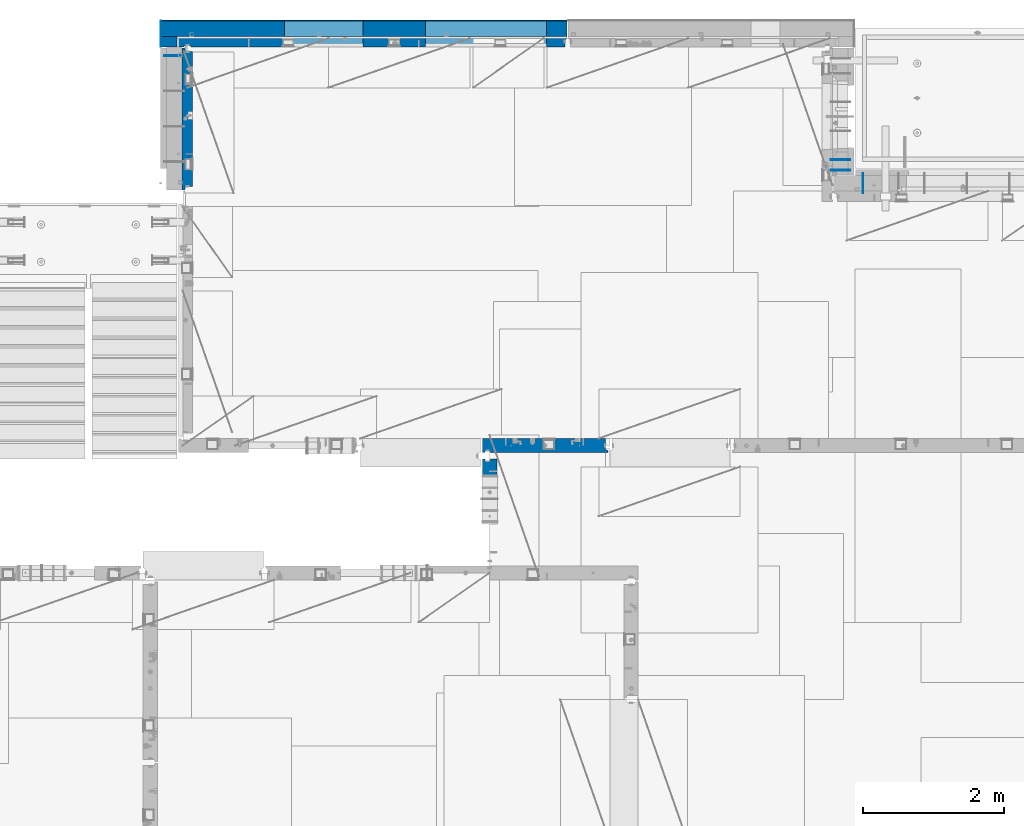
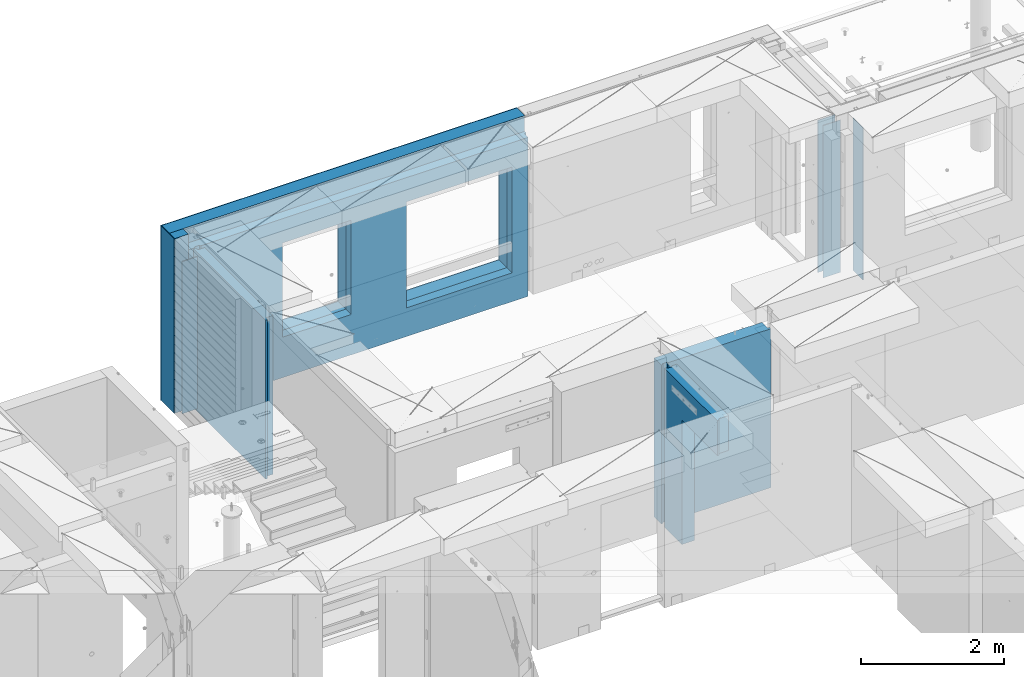
# One storey, part 228 of 334: 12 walls, 6 elements without a shape of their own.
"""IFC2X3 building model written with IfcOpenShell, lengths in millimetres."""

from ifc_helpers import new_model, si_unit, frame, origin_with_axes, place, context, subcontext, project, spatial, faceted_brep, material, type_object, element, aggregate, save


model = new_model("IFC2X3")

# Units and contexts
model_context = context("Model", 3, precision=1e-05, world=origin_with_axes())
body_context = subcontext(model_context, "Body", "Model", "MODEL_VIEW")
ifc_project = project(units=[si_unit("LENGTHUNIT", "METRE", prefix="MILLI"), si_unit("AREAUNIT", "SQUARE_METRE"), si_unit("VOLUMEUNIT", "CUBIC_METRE"), si_unit("MASSUNIT", "GRAM", prefix="KILO"), si_unit("TIMEUNIT", "SECOND"), si_unit("PLANEANGLEUNIT", "RADIAN"), si_unit("SOLIDANGLEUNIT", "STERADIAN"), si_unit("THERMODYNAMICTEMPERATUREUNIT", "DEGREE_CELSIUS"), si_unit("LUMINOUSINTENSITYUNIT", "LUMEN")], contexts=[model_context])

# Site, building, storey
site_placement = place(None, origin_with_axes())
site = spatial("IfcSite", under=ifc_project, at=site_placement, CompositionType="ELEMENT")
building_placement = place(site_placement, origin_with_axes())
building = spatial("IfcBuilding", under=site, at=building_placement, CompositionType="ELEMENT")
storey_placement = place(building_placement, origin_with_axes())
storey = spatial("IfcBuildingStorey", under=building, at=storey_placement, Name="3", CompositionType="ELEMENT", Elevation=0.0)

# Assembly, wall
assembly_1_placement = place(storey_placement, origin_with_axes())
assembly_1 = element("IfcElementAssembly", 1, at=assembly_1_placement, inside=storey, AssemblyPlace="NOTDEFINED", PredefinedType="REINFORCEMENT_UNIT")
ifc_material_1 = material(Name="Undefined")
wall_type_1 = type_object("IfcWallType", PredefinedType="NOTDEFINED")
wall_1_placement = place(assembly_1_placement, frame((22290.0, 22495.0, 89110.0), z_axis=(0.0, 0.0, 1.0), x_axis=(-1.0, 3.00000001838171e-08, 0.0)))
wall_1 = element("IfcWall", 2, at=wall_1_placement, type_object=wall_type_1, material=ifc_material_1, Name="(PD)", context=body_context, shape_type="Brep", body=[
    faceted_brep([(0.0, 5.0, -1300.0), (0.0, 5.0, 1300.0), (280.0, 5.0, 1300.0), (280.0, 5.0, -1300.0), (0.0, -5.0, 1300.0), (280.0, -5.0, 1300.0), (0.0, -5.0, -1300.0), (280.0, -5.0, -1300.0)], [[[0, 1, 2, 3]], [[1, 4, 5, 2]], [[4, 6, 7, 5]], [[6, 0, 3, 7]], [[5, 7, 3, 2]], [[6, 4, 1, 0]]]),
])

assembly_2_placement = place(storey_placement, origin_with_axes())
assembly_2 = element("IfcElementAssembly", 3, at=assembly_2_placement, inside=storey, AssemblyPlace="NOTDEFINED", PredefinedType="REINFORCEMENT_UNIT")
wall_2_placement = place(assembly_2_placement, frame((31890.0, 20549.9951872276, 89115.0), z_axis=(0.0, 0.0, 1.0), x_axis=(0.0, 1.0, 0.0)))
wall_2 = element("IfcWall", 4, at=wall_2_placement, type_object=wall_type_1, material=ifc_material_1, Name="(PD)", context=body_context, shape_type="Brep", body=[
    faceted_brep([(0.0, 5.0, -1300.0), (0.0, 5.0, 1300.0), (280.0, 5.0, 1300.0), (280.0, 5.0, -1300.0), (0.0, -5.0, 1300.0), (280.0, -5.0, 1300.0), (0.0, -5.0, -1300.0), (280.0, -5.0, -1300.0)], [[[0, 1, 2, 3]], [[1, 4, 5, 2]], [[4, 6, 7, 5]], [[6, 0, 3, 7]], [[5, 7, 3, 2]], [[6, 4, 1, 0]]]),
])
aggregate(assembly_2, [wall_2])

# Assembly, walls
assembly_3_placement = place(storey_placement, origin_with_axes())
assembly_3 = element("IfcElementAssembly", 5, at=assembly_3_placement, inside=storey, AssemblyPlace="NOTDEFINED", PredefinedType="REINFORCEMENT_UNIT")
wall_3_placement = place(assembly_3_placement, frame((31429.9951872276, 20875.0, 89115.0), z_axis=(0.0, 0.0, 1.0), x_axis=(1.0, 0.0, 0.0)))
wall_3 = element("IfcWall", 6, at=wall_3_placement, type_object=wall_type_1, material=ifc_material_1, Name="(PD)", context=body_context, shape_type="Brep", body=[
    faceted_brep([(0.0, 5.0, -1300.0), (0.0, 5.0, 1300.0), (280.0, 5.0, 1300.0), (280.0, 5.0, -1300.0), (0.0, -5.0, 1300.0), (280.0, -5.0, 1300.0), (0.0, -5.0, -1300.0), (280.0, -5.0, -1300.0)], [[[0, 1, 2, 3]], [[1, 4, 5, 2]], [[4, 6, 7, 5]], [[6, 0, 3, 7]], [[5, 7, 3, 2]], [[6, 4, 1, 0]]]),
])
wall_4_placement = place(assembly_3_placement, frame((31429.9951872276, 21025.0, 89115.0), z_axis=(0.0, 0.0, 1.0), x_axis=(1.0, 0.0, 0.0)))
wall_4 = element("IfcWall", 7, at=wall_4_placement, type_object=wall_type_1, material=ifc_material_1, Name="(PD)", context=body_context, shape_type="Brep", body=[
    faceted_brep([(0.0, 5.0, -1300.0), (0.0, 5.0, 1300.0), (280.0, 5.0, 1300.0), (280.0, 5.0, -1300.0), (0.0, -5.0, 1300.0), (280.0, -5.0, 1300.0), (0.0, -5.0, -1300.0), (280.0, -5.0, -1300.0)], [[[0, 1, 2, 3]], [[1, 4, 5, 2]], [[4, 6, 7, 5]], [[6, 0, 3, 7]], [[5, 7, 3, 2]], [[6, 4, 1, 0]]]),
])
aggregate(assembly_3, [wall_3, wall_4])

# Assembly, wall
assembly_4_placement = place(storey_placement, origin_with_axes())
assembly_4 = element("IfcElementAssembly", 8, at=assembly_4_placement, inside=storey, AssemblyPlace="NOTDEFINED", PredefinedType="REINFORCEMENT_UNIT")
ifc_material_2 = material(Name="CONCRETE/C25/30")
wall_type_2 = type_object("IfcWallType", PredefinedType="NOTDEFINED")
wall_5_placement = place(assembly_4_placement, frame((26609.9991475894, 15280.0004107749, 89112.5), z_axis=(0.0, 0.0, 1.0), x_axis=(0.0, 1.0, 0.0)))
wall_5 = element("IfcWall", 9, at=wall_5_placement, type_object=wall_type_2, material=ifc_material_2, context=body_context, shape_type="Brep", body=[
    faceted_brep([(1509.99949975397, 70.0, 1357.5), (1489.99949975397, 70.0, 1357.5), (1489.99949975397, 70.0, -1357.5), (1509.99949975397, 70.0, -1357.5), (1489.99949975397, -10.0, 1357.5), (1489.99949975397, -10.0, -1357.5), (1509.99949975397, -10.0, 1357.5), (1509.99949975397, -10.0, -1357.5), (29.9995892251427, 70.0, 1357.5), (29.9995892251427, 70.0, 762.5), (59.9995892251427, 57.0, 762.5), (59.9995892251427, 57.0, 1357.5), (29.9995892251427, 100.0, 1357.5), (29.9995892251427, 100.0, 762.5), (1509.99949975397, 100.0, 1357.5), (1509.99949975397, 100.0, -1357.5), (1019.99979369292, 100.0, -1357.5), (1019.99979369292, 100.0, 762.5), (1019.99979369292, -100.0, 762.5), (1019.99979369292, -100.0, -1357.5), (59.9995892251427, -100.0, 762.5), (59.9995892251427, -100.0, 1357.5), (1509.99949975397, -100.0, -1357.5), (1509.99949975397, -100.0, 1357.5)], [[[0, 1, 2, 3]], [[4, 5, 2, 1]], [[6, 7, 5, 4]], [[8, 9, 10, 11]], [[12, 13, 9, 8]], [[12, 14, 15, 16, 17, 13]], [[18, 17, 16, 19]], [[9, 13, 17, 18, 20, 10]], [[21, 11, 10, 20]], [[18, 19, 22, 23, 21, 20]], [[1, 0, 14, 12, 8, 11, 21, 23, 6, 4]], [[15, 14, 0, 3]], [[22, 19, 16, 15, 3, 2, 5, 7]], [[23, 22, 7, 6]]]),
])
aggregate(assembly_4, [wall_5])

assembly_5_placement = place(storey_placement, origin_with_axes())
assembly_5 = element("IfcElementAssembly", 10, at=assembly_5_placement, inside=storey, AssemblyPlace="NOTDEFINED", PredefinedType="REINFORCEMENT_UNIT")
wall_6_placement = place(assembly_5_placement, frame((26510.0014364077, 16980.0, 89112.5), z_axis=(0.0, 0.0, 1.0), x_axis=(1.0, 0.0, 0.0)))
wall_6 = element("IfcWall", 11, at=wall_6_placement, type_object=wall_type_2, material=ifc_material_2, context=body_context, shape_type="Brep", body=[
    faceted_brep([(1739.99847412109, 100.0, 1357.5), (1739.99847412109, -57.0, 1357.5), (1739.99847412109, -57.0, -1357.5), (1739.99847412109, 100.0, -1357.5), (1769.99847412109, -70.0, 1357.5), (1769.99847412109, -70.0, -1357.5), (0.0, -100.0, -1357.5), (0.0, -100.0, 1357.5), (0.0, 100.0, 1357.5), (0.0, 100.0, -1357.5), (29.998563592264, -100.0, -1357.5), (29.998563592264, -100.0, 1357.5), (29.998563592264, -80.0008544921875, -1357.5), (29.998563592264, -80.0008544921875, 1357.5), (109.998563592264, -80.0008544921875, -1357.5), (109.998563592264, -80.0008544921875, 1357.5), (109.998563592264, -100.0, -1357.5), (109.998563592264, -100.0, 1357.5), (1769.99847412109, -100.0, -1357.5), (1769.99847412109, -100.0, 1357.5)], [[[0, 1, 2, 3]], [[4, 5, 2, 1]], [[6, 7, 8, 9]], [[7, 6, 10, 11]], [[11, 10, 12, 13]], [[13, 12, 14, 15]], [[15, 14, 16, 17]], [[18, 19, 17, 16]], [[0, 8, 7, 11, 13, 15, 17, 19, 4, 1]], [[9, 8, 0, 3]], [[18, 16, 14, 12, 10, 6, 9, 3, 2, 5]], [[19, 18, 5, 4]]]),
])
aggregate(assembly_5, [wall_6])

# Assembly, walls
assembly_6_placement = place(storey_placement, origin_with_axes())
assembly_6 = element("IfcElementAssembly", 12, at=assembly_6_placement, inside=storey, AssemblyPlace="NOTDEFINED", PredefinedType="REINFORCEMENT_UNIT")
ifc_material_3 = material()
wall_type_3 = type_object("IfcWallType", PredefinedType="NOTDEFINED")
wall_7_placement = place(assembly_6_placement, frame((22075.0, 22620.0, 89247.5), z_axis=(0.0, 0.0, 1.0), x_axis=(0.0, 1.0, 0.0)))
wall_7 = element("IfcWall", 13, at=wall_7_placement, type_object=wall_type_3, material=ifc_material_3, context=body_context, shape_type="Brep", body=[
    faceted_brep([(0.0, 110.0, -1492.5), (0.0, 110.0, 1492.5), (150.0, 110.0, 1492.5), (150.0, 110.0, -1492.5), (0.0, -110.0, 1492.5), (150.0, -110.0, 1492.5), (0.0, -110.0, -1492.5), (150.0, -110.0, -1492.5)], [[[0, 1, 2, 3]], [[1, 4, 5, 2]], [[4, 6, 7, 5]], [[6, 0, 3, 7]], [[5, 7, 3, 2]], [[6, 4, 1, 0]]]),
])
wall_8_placement = place(assembly_6_placement, frame((22260.0, 22880.0, 89247.5), z_axis=(0.0, 0.0, 1.0), x_axis=(1.0, 0.0, 0.0)))
wall_8 = element("IfcWall", 14, at=wall_8_placement, type_object=wall_type_3, material=ifc_material_3, context=body_context, shape_type="Brep", body=[
    faceted_brep([(-295.0, 110.0, 1492.5), (-295.0, -110.0, 1492.5), (5445.0, -110.0, 1492.5), (5445.0, 110.0, 1492.5), (-295.0, -110.0, -1492.5), (-295.0, 110.0, -1492.5), (5445.0, 110.0, -1492.5), (5445.0, -110.0, -1492.5), (3445.00100868184, 110.0, -1002.5), (5155.00100868184, 110.0, -1002.5), (5155.00100868184, 110.0, 807.5), (3445.00100868184, 110.0, 807.5), (1444.99910133321, 110.0, -802.5), (2554.99910133321, 110.0, -802.5), (2554.99910133321, 110.0, 807.5), (1444.99910133321, 110.0, 807.5), (1444.99910133321, -110.0, -802.5), (2554.99910133321, -110.0, -802.5), (1444.99910133321, -110.0, 807.5), (2554.99910133321, -110.0, 807.5), (3445.00100868184, -110.0, -1002.5), (3445.00100868184, -110.0, 807.5), (5155.00100868184, -110.0, 807.5), (5155.00100868184, -110.0, -1002.5)], [[[0, 1, 2, 3]], [[4, 1, 0, 5]], [[4, 5, 6, 7]], [[2, 7, 6, 3]], [[5, 0, 3, 6], [8, 9, 10, 11], [12, 13, 14, 15]], [[12, 16, 17, 13]], [[15, 18, 16, 12]], [[14, 19, 18, 15]], [[13, 17, 19, 14]], [[1, 4, 7, 2], [20, 21, 22, 23], [16, 18, 19, 17]], [[10, 22, 21, 11]], [[9, 23, 22, 10]], [[8, 20, 23, 9]], [[11, 21, 20, 8]]]),
])
wall_type_4 = type_object("IfcWallType", PredefinedType="NOTDEFINED")
wall_9_placement = place(assembly_6_placement, frame((22185.0, 22695.0, 89112.5), z_axis=(0.0, 0.0, 1.0), x_axis=(1.0, 0.0, 0.0)))
wall_9 = element("IfcWall", 15, at=wall_9_placement, type_object=wall_type_4, material=ifc_material_2, context=body_context, shape_type="Brep", body=[
    faceted_brep([(3520.00100868184, 75.0, 942.5), (3520.00100868184, -75.0000008199713, 942.5), (3520.00100868184, -75.0000000602631, -867.5), (3520.00100868184, 75.0, -867.5), (5230.00100868184, -74.9999996918959, -867.5), (5230.00100868184, 75.0, -867.5), (5230.00100868184, -75.0000004516041, 942.5), (5230.00100868184, 75.0, 942.5), (5490.0, -75.0, 1357.5), (5490.0, -75.0, -1357.5), (5490.0, 24.9999980926514, -1357.5), (5490.0, 24.9999980926514, 1357.5), (5520.0, 45.0, 1357.5), (5520.0, 75.0, 1357.5), (0.0, 75.0, 1357.5), (0.0, -75.0, 1357.5), (100.0, -75.0, 1357.5), (110.0, -55.0000022791319, 1357.5), (190.0, -55.0000022791319, 1357.5), (200.0, -75.0000022791319, 1357.5), (0.0, -75.0, -1357.5), (0.0, 75.0, -1357.5), (100.0, -75.0, -1357.5), (110.0, -55.0000022791319, -1357.5), (190.0, -55.0000022791319, -1357.5), (200.0, -75.0, -1357.5), (5520.0, 75.0, -1357.5), (5520.0, 45.0, -1357.5), (1519.99910133321, 75.0, -667.5), (2629.99910133321, 75.0, -667.5), (2629.99910133321, 75.0, 942.5), (1519.99910133321, 75.0, 942.5), (1519.99910133321, -75.0000005750444, -667.5), (2629.99910133321, -75.0000003359273, -667.5), (1519.99910133321, -75.0000012508099, 942.5), (2629.99910133321, -75.0000010116928, 942.5)], [[[0, 1, 2, 3]], [[3, 2, 4, 5]], [[5, 4, 6, 7]], [[7, 6, 1, 0]], [[8, 9, 10, 11]], [[8, 11, 12, 13, 14, 15, 16, 17, 18, 19]], [[20, 15, 14, 21]], [[15, 20, 22, 16]], [[16, 22, 23, 17]], [[17, 23, 24, 18]], [[19, 18, 24, 25]], [[23, 22, 20, 21, 26, 27, 10, 9, 25, 24]], [[12, 11, 10, 27]], [[26, 13, 12, 27]], [[21, 14, 13, 26], [3, 5, 7, 0], [28, 29, 30, 31]], [[28, 32, 33, 29]], [[31, 34, 32, 28]], [[30, 35, 34, 31]], [[29, 33, 35, 30]], [[9, 8, 19, 25], [2, 1, 6, 4], [32, 34, 35, 33]]]),
])

# Wall
wall_10_placement = place(assembly_1_placement, frame((22335.0, 20595.0, 89112.5), z_axis=(0.0, 0.0, 1.0), x_axis=(0.0, 1.0, 0.0)))
wall_10 = element("IfcWall", 16, at=wall_10_placement, type_object=wall_type_4, material=ifc_material_2, context=body_context, shape_type="Brep", body=[
    faceted_brep([(0.0, 40.0, 1357.5), (0.0, 40.0, -1357.5), (50.0, 27.0, -1357.5), (50.0, 27.0, 1357.5), (50.0, -75.0, 1357.5), (50.0, -75.0, -1357.5), (0.0, 75.0, -1357.5), (0.0, 75.0, 1357.5), (2009.99999772087, 75.0, 1357.5), (2009.99999772087, 75.0, -1357.5), (2009.99999772087, 40.0, 1357.5), (2009.99999772087, 40.0, -1357.5), (1959.99999772087, 27.0, 1357.5), (1959.99999772087, 27.0, -1357.5), (1959.99999772087, -75.0, 1357.5), (1959.99999772087, -75.0, -1357.5)], [[[0, 1, 2, 3]], [[4, 3, 2, 5]], [[6, 7, 8, 9]], [[9, 8, 10, 11]], [[12, 13, 11, 10]], [[14, 15, 13, 12]], [[15, 14, 4, 5]], [[1, 6, 9, 11, 13, 15, 5, 2]], [[7, 6, 1, 0]], [[14, 12, 10, 8, 7, 0, 3, 4]]]),
])

aggregate(assembly_1, [wall_1, wall_10])

ifc_material_4 = material(Name="CONCRETE/C30/37")
wall_type_5 = type_object("IfcWallType", PredefinedType="NOTDEFINED")
wall_11_placement = place(assembly_6_placement, frame((21960.0001313636, 22620.0, 89247.5), z_axis=(0.0, 0.0, 1.0), x_axis=(0.0, 1.0, 0.0)))
wall_11 = element("IfcWall", 17, at=wall_11_placement, type_object=wall_type_5, material=ifc_material_4, context=body_context, shape_type="Brep", body=[
    faceted_brep([(0.0, 5.0, -1492.5), (0.0, 5.0, 1492.5), (370.0, 5.0, 1492.5), (370.0, 5.0, -1492.5), (0.0, -5.0, 1492.5), (370.0, -5.0, 1492.5), (0.0, -5.0, -1492.5), (370.0, -5.0, -1492.5)], [[[0, 1, 2, 3]], [[1, 4, 5, 2]], [[4, 6, 7, 5]], [[6, 0, 3, 7]], [[5, 7, 3, 2]], [[6, 4, 1, 0]]]),
])

wall_12_placement = place(assembly_6_placement, frame((22260.0, 22995.0, 89247.5), z_axis=(0.0, 0.0, 1.0), x_axis=(1.0, 0.0, 0.0)))
wall_12 = element("IfcWall", 18, at=wall_12_placement, type_object=wall_type_5, material=ifc_material_4, context=body_context, shape_type="Brep", body=[
    faceted_brep([(-305.0, 5.0, 1492.5), (-305.0, -5.0, 1492.5), (5445.0, -5.0, 1492.5), (5445.0, 5.0, 1492.5), (-305.0, -5.0, -1492.5), (-305.0, 5.0, -1492.5), (5445.0, 5.0, -1492.5), (5445.0, -5.0, -1492.5), (3445.00100868184, 5.0, -1002.5), (5155.00100868184, 5.0, -1002.5), (5155.00100868184, 5.0, 807.5), (3445.00100868184, 5.0, 807.5), (1444.99910133321, 5.0, -802.5), (2554.99910133321, 5.0, -802.5), (2554.99910133321, 5.0, 807.5), (1444.99910133321, 5.0, 807.5), (1444.99910133321, -5.0, -802.5), (2554.99910133321, -5.0, -802.5), (1444.99910133321, -5.0, 807.5), (2554.99910133321, -5.0, 807.5), (3445.00100868184, -5.0, -1002.5), (3445.00100868184, -5.0, 807.5), (5155.00100868184, -5.0, 807.5), (5155.00100868184, -5.0, -1002.5)], [[[0, 1, 2, 3]], [[4, 1, 0, 5]], [[4, 5, 6, 7]], [[2, 7, 6, 3]], [[5, 0, 3, 6], [8, 9, 10, 11], [12, 13, 14, 15]], [[12, 16, 17, 13]], [[15, 18, 16, 12]], [[14, 19, 18, 15]], [[13, 17, 19, 14]], [[1, 4, 7, 2], [20, 21, 22, 23], [16, 18, 19, 17]], [[10, 22, 21, 11]], [[9, 23, 22, 10]], [[8, 20, 23, 9]], [[11, 21, 20, 8]]]),
])

aggregate(assembly_6, [wall_11, wall_7, wall_9, wall_8, wall_12])

save(model, "model.ifc")
